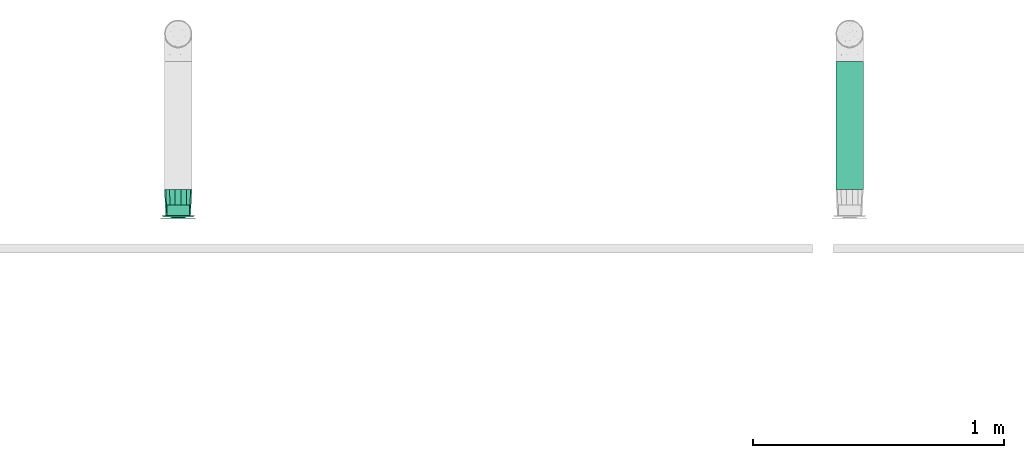
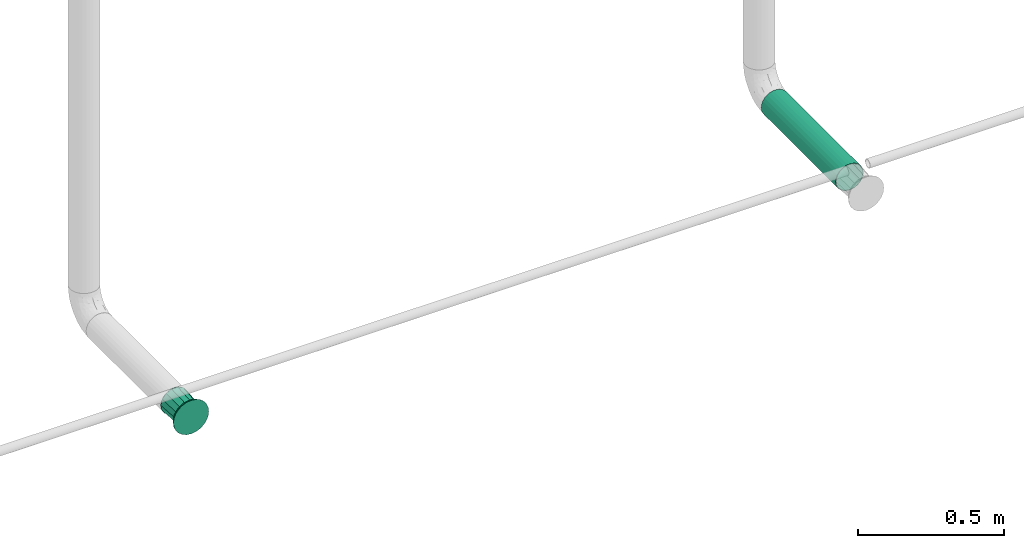
# One storey, part 93 of 123: 1 flow fitting, 1 flow segment, 1 flow terminal.
"""IFC2X3 building model written with IfcOpenShell, lengths in millimetres."""

from ifc_helpers import new_model, entity, si_unit, converted_unit, derived_unit, direction, frame, origin_with_axes, origin_2d_with_axis, place, context, subcontext, project, spatial, hollow_circle, extrude, open_shell, surface_model, source, transform, mapped, material, layer, layer_set, layer_usage, type_object, element, save


model = new_model("IFC2X3")

# Units and contexts
model_context = context("Model", 3, precision=1e-05, world=origin_with_axes(), true_north=direction((0.0, 1.0)))
body_context = subcontext(model_context, "Body", "Model", "MODEL_VIEW")
ifc_project = project(units=[si_unit("AREAUNIT", "SQUARE_METRE"), si_unit("VOLUMEUNIT", "CUBIC_METRE", prefix="DECI"), si_unit("TIMEUNIT", "SECOND"), si_unit("THERMODYNAMICTEMPERATUREUNIT", "DEGREE_CELSIUS"), si_unit("PRESSUREUNIT", "PASCAL"), si_unit("MASSUNIT", "GRAM", prefix="KILO"), si_unit("LENGTHUNIT", "METRE", prefix="MILLI"), si_unit("POWERUNIT", "WATT"), si_unit("ELECTRICCURRENTUNIT", "AMPERE"), si_unit("ELECTRICVOLTAGEUNIT", "VOLT"), derived_unit("VOLUMETRICFLOWRATEUNIT", [(si_unit("VOLUMEUNIT", "CUBIC_METRE", prefix="DECI"), 1), (si_unit("TIMEUNIT", "SECOND"), -1)]), derived_unit("LINEARVELOCITYUNIT", [(si_unit("LENGTHUNIT", "METRE"), 1), (si_unit("TIMEUNIT", "SECOND"), -1)]), derived_unit("MASSDENSITYUNIT", [(si_unit("MASSUNIT", "GRAM", prefix="KILO"), 1), (si_unit("VOLUMEUNIT", "CUBIC_METRE"), -1)]), converted_unit("PLANEANGLEUNIT", "DEGREE", entity("IfcRatioMeasure", 0.01745), si_unit("PLANEANGLEUNIT", "RADIAN"), dimensions=[0, 0, 0, 0, 0, 0, 0])], contexts=[model_context])

# Site, building, storey
site_placement = place(None, origin_with_axes())
site = spatial("IfcSite", under=ifc_project, at=site_placement, CompositionType="ELEMENT")
building_placement = place(site_placement, origin_with_axes())
building = spatial("IfcBuilding", under=site, at=building_placement, Name="mc-building", CompositionType="ELEMENT")
storey_placement = place(building_placement, origin_with_axes())
storey = spatial("IfcBuildingStorey", under=building, at=storey_placement, Name="1. Korrus", CompositionType="ELEMENT", Elevation=0.0)

# Flow terminal
air_terminal_type = type_object("IfcAirTerminalType", Name="100", PredefinedType="NOTDEFINED")
shared_shape_1 = source(origin_with_axes(), body_context, "Body", "SurfaceModel", [
    surface_model("IfcShellBasedSurfaceModel", [(11.2, 18.11733, -67.61481), (11.2, -18.11733, -67.61481), (11.2, 0.0, -70.0), (11.2, 67.61481, -18.11733), (11.2, 35.0, -60.62178), (11.2, 49.49747, -49.49747), (11.2, 60.62178, -35.0), (11.2, -67.61481, 18.11733), (11.2, -49.49747, -49.49747), (11.2, -67.61481, -18.11733), (11.2, -35.0, -60.62178), (11.2, -60.62178, -35.0), (11.2, -70.0, 0.0), (11.2, 18.11733, 67.61481), (11.2, 70.0, 0.0), (11.2, 67.61481, 18.11733), (11.2, 49.49747, 49.49747), (11.2, 60.62178, 35.0), (11.2, 35.0, 60.62178), (11.2, -49.49747, 49.49747), (11.2, -60.62178, 35.0), (11.2, -35.0, 60.62178), (11.2, -18.11733, 67.61481), (11.2, 0.0, 70.0), (9.2, 18.11733, 67.61481), (9.2, -67.61481, 18.11733), (9.2, 0.0, 70.0), (9.2, 49.49747, 49.49747), (9.2, 35.0, 60.62178), (9.2, 60.62178, 35.0), (9.2, 67.61481, 18.11733), (9.2, -35.0, 60.62178), (9.2, -49.49747, 49.49747), (9.2, -18.11733, 67.61481), (9.2, -60.62178, 35.0), (9.2, -67.61481, -18.11733), (9.2, -70.0, 0.0), (9.2, 67.61481, -18.11733), (9.2, 18.11733, -67.61481), (9.2, 49.49747, -49.49747), (9.2, 60.62178, -35.0), (9.2, 35.0, -60.62178), (9.2, -18.11733, -67.61481), (9.2, -49.49747, -49.49747), (9.2, -60.62178, -35.0), (9.2, -35.0, -60.62178), (9.2, 0.0, -70.0), (9.2, 70.0, 0.0), (9.2, 32.75, 0.0), (9.2, -16.375, 28.36233), (9.2, -28.36233, 16.375), (9.2, 16.375, 28.36233), (9.2, 0.0, 32.75), (9.2, 28.36233, 16.375), (9.2, -32.75, 0.0), (9.2, -16.375, -28.36233), (9.2, 16.375, -28.36233), (9.2, 0.0, -32.75), (9.2, 28.36233, -16.375), (9.2, -28.36233, -16.375), (6.2, -21.19625, -15.39997), (6.2, -21.19625, 15.39997), (6.2, 8.09625, 24.91768), (6.2, -8.09625, 24.91768), (6.2, -26.2, 0.0), (6.2, 21.19625, 15.39997), (6.2, -8.09625, -24.91768), (6.2, 21.19625, -15.39997), (6.2, 8.09625, -24.91768), (6.2, 26.2, 0.0), (9.2, 31.06579, -6.28555), (6.2, 23.69812, -7.69999), (6.2, -14.64625, -20.15883), (9.2, -22.36867, -22.36867), (6.2, -23.69812, -7.69999), (9.2, -31.06579, -6.28555), (6.2, 14.64625, -20.15883), (9.2, 8.1875, -30.55617), (6.2, 0.0, -24.91768), (9.2, 22.36867, -22.36867), (9.2, -8.1875, -30.55617), (9.2, -31.06579, 6.28555), (6.2, -23.69812, 7.69999), (6.2, 14.64625, 20.15883), (9.2, 22.36867, 22.36867), (6.2, 23.69812, 7.69999), (9.2, 31.06579, 6.28555), (6.2, -14.64625, 20.15883), (9.2, -8.1875, 30.55617), (6.2, 0.0, 24.91768), (9.2, -22.36867, 22.36867), (9.2, 8.1875, 30.55617), (6.2, -13.11761, 57.472), (6.2, -36.75472, 46.08897), (6.2, -53.11211, 25.57744), (6.2, 36.75472, 46.08897), (6.2, -58.95, 0.0), (6.2, 13.11761, 57.472), (6.2, 53.11211, 25.57744), (6.2, -53.11211, -25.57744), (6.2, -36.75472, -46.08897), (6.2, -13.11761, -57.472), (6.2, 58.95, 0.0), (6.2, 53.11211, -25.57744), (6.2, 13.11761, -57.472), (6.2, 36.75472, -46.08897), (0.0, -60.51411, 25.06576), (0.0, 0.0, 65.5), (0.0, 25.06576, 60.51411), (0.0, 46.3155, 46.3155), (0.0, 60.51411, 25.06576), (0.0, -46.3155, 46.3155), (0.0, -25.06576, 60.51411), (0.0, 0.0, -65.5), (0.0, -65.5, 0.0), (0.0, 65.5, 0.0), (0.0, 60.51411, -25.06576), (0.0, 46.3155, -46.3155), (0.0, 25.06576, -60.51411), (0.0, -46.3155, -46.3155), (0.0, -60.51411, -25.06576), (0.0, -25.06576, -60.51411), (6.2, 56.03105, -12.78872), (0.0, 53.4148, -35.69063), (0.0, 35.69063, -53.4148), (6.2, 24.93616, -51.78048), (0.0, -12.53288, -63.00706), (6.2, 0.0, -57.472), (0.0, -35.69063, -53.4148), (0.0, 63.00706, -12.53288), (6.2, 44.93342, -35.83321), (6.2, -24.93616, -51.78048), (6.2, -44.93342, -35.83321), (0.0, -53.4148, -35.69063), (0.0, 12.53288, -63.00706), (6.2, -56.03105, -12.78872), (0.0, -63.00706, -12.53288), (6.2, -56.03105, 12.78872), (0.0, -53.4148, 35.69063), (0.0, -35.69063, 53.4148), (6.2, -24.93616, 51.78048), (0.0, 12.53288, 63.00706), (6.2, 0.0, 57.472), (0.0, 35.69063, 53.4148), (0.0, -63.00706, 12.53288), (6.2, -44.93342, 35.83321), (6.2, 24.93616, 51.78048), (6.2, 44.93342, 35.83321), (0.0, 53.4148, 35.69063), (0.0, -12.53288, 63.00706), (6.2, 56.03105, 12.78872), (0.0, 63.00706, 12.53288), (-3.1, 12.94095, 48.29629), (-3.1, -35.35534, 35.35534), (-3.1, 0.0, 50.0), (-3.1, 35.35534, 35.35534), (-3.1, 25.0, 43.30127), (-3.1, -43.30127, 25.0), (-3.1, 43.30127, 25.0), (-3.1, -48.29629, -12.94095), (-3.1, -12.94095, 48.29629), (-3.1, -25.0, 43.30127), (-3.1, -50.0, 0.0), (-3.1, -48.29629, 12.94095), (-3.1, 48.29629, 12.94095), (-3.1, 12.94095, -48.29629), (-3.1, 50.0, 0.0), (-3.1, 48.29629, -12.94095), (-3.1, 35.35534, -35.35534), (-3.1, 43.30127, -25.0), (-3.1, 25.0, -43.30127), (-3.1, 0.0, -50.0), (-3.1, -35.35534, -35.35534), (-3.1, -43.30127, -25.0), (-3.1, -25.0, -43.30127), (-3.1, -12.94095, -48.29629), (0.0, 25.0, -43.30127), (0.0, 0.0, -50.0), (0.0, 12.94095, -48.29629), (0.0, 48.29629, -12.94095), (0.0, 35.35534, -35.35534), (0.0, -25.0, -43.30127), (0.0, 43.30127, -25.0), (0.0, -50.0, 0.0), (0.0, -12.94095, -48.29629), (0.0, -35.35534, -35.35534), (0.0, -48.29629, -12.94095), (0.0, -43.30127, -25.0), (0.0, 50.0, 0.0), (0.0, 43.30127, 25.0), (0.0, 12.94095, 48.29629), (0.0, 35.35534, 35.35534), (0.0, 25.0, 43.30127), (0.0, 0.0, 50.0), (0.0, -35.35534, 35.35534), (0.0, -43.30127, 25.0), (0.0, -48.29629, 12.94095), (0.0, -12.94095, 48.29629), (0.0, -25.0, 43.30127), (0.0, 48.29629, 12.94095), (-43.1, 0.0, 45.0), (-43.1, 11.64686, 43.46666), (-43.1, 22.5, 38.97115), (-43.1, -11.64686, 43.46666), (-43.1, 38.97115, 22.5), (-43.1, 43.46666, 11.64686), (-43.1, 31.81981, 31.81981), (-43.1, -22.5, 38.97115), (-43.1, -43.46666, 11.64686), (-43.1, -31.81981, 31.81981), (-43.1, -38.97115, 22.5), (-43.1, -45.0, 0.0), (-43.1, -43.46666, -11.64686), (-43.1, 45.0, 0.0), (-43.1, 43.46666, -11.64686), (-43.1, 38.97115, -22.5), (-43.1, 31.81981, -31.81981), (-43.1, 22.5, -38.97115), (-43.1, 11.64686, -43.46666), (-43.1, -31.81981, -31.81981), (-43.1, -38.97115, -22.5), (-43.1, -22.5, -38.97115), (-43.1, 0.0, -45.0), (-43.1, -11.64686, -43.46666), (-3.1, 22.5, -38.97115), (-3.1, 0.0, -45.0), (-3.1, 11.64686, -43.46666), (-3.1, 31.81981, -31.81981), (-3.1, -22.5, -38.97115), (-3.1, 38.97115, -22.5), (-3.1, 43.46666, -11.64686), (-3.1, 45.0, 0.0), (-3.1, -45.0, 0.0), (-3.1, -11.64686, -43.46666), (-3.1, -31.81981, -31.81981), (-3.1, -43.46666, -11.64686), (-3.1, -38.97115, -22.5), (-3.1, 0.0, 45.0), (-3.1, 43.46666, 11.64686), (-3.1, 38.97115, 22.5), (-3.1, 22.5, 38.97115), (-3.1, 31.81981, 31.81981), (-3.1, 11.64686, 43.46666), (-3.1, -11.64686, 43.46666), (-3.1, -43.46666, 11.64686), (-3.1, -31.81981, 31.81981), (-3.1, -38.97115, 22.5), (-3.1, -22.5, 38.97115)], [open_shell([[[0, 1, 2]], [[3, 0, 4]], [[5, 6, 3]], [[5, 3, 4]], [[7, 1, 0]], [[8, 7, 9]], [[10, 7, 8]], [[8, 9, 11]], [[12, 9, 7]], [[1, 7, 10]], [[7, 0, 3]], [[13, 14, 15]], [[16, 15, 17]], [[16, 18, 13]], [[16, 13, 15]], [[14, 13, 7]], [[7, 19, 20]], [[19, 7, 21]], [[7, 22, 21]], [[22, 7, 23]], [[7, 13, 23]], [[14, 7, 3]], [[24, 25, 26]], [[27, 24, 28]], [[27, 29, 30]], [[27, 30, 24]], [[25, 24, 30]], [[31, 25, 32]], [[25, 31, 33]], [[32, 25, 34]], [[33, 26, 25]], [[25, 35, 36]], [[25, 30, 37]], [[25, 37, 38]], [[39, 37, 40]], [[39, 41, 38]], [[39, 38, 37]], [[38, 42, 25]], [[35, 43, 44]], [[35, 25, 43]], [[45, 43, 25]], [[42, 45, 25]], [[38, 46, 42]], [[37, 30, 47]], [[35, 9, 36]], [[44, 11, 35]], [[10, 43, 45]], [[44, 43, 8]], [[1, 45, 42]], [[35, 11, 9]], [[9, 12, 36]], [[1, 10, 45]], [[8, 43, 10]], [[8, 11, 44]], [[2, 1, 42]], [[42, 46, 2]], [[38, 0, 46]], [[41, 4, 38]], [[6, 39, 40]], [[41, 39, 5]], [[3, 40, 37]], [[41, 5, 4]], [[4, 0, 38]], [[14, 3, 37]], [[6, 40, 3]], [[6, 5, 39]], [[47, 14, 37]], [[46, 0, 2]], [[30, 15, 47]], [[29, 17, 30]], [[18, 27, 28]], [[29, 27, 16]], [[13, 28, 24]], [[30, 17, 15]], [[15, 14, 47]], [[13, 18, 28]], [[16, 27, 18]], [[16, 17, 29]], [[23, 13, 24]], [[24, 26, 23]], [[33, 22, 26]], [[31, 21, 33]], [[20, 32, 34]], [[31, 32, 19]], [[7, 34, 25]], [[31, 19, 21]], [[21, 22, 33]], [[12, 7, 25]], [[20, 34, 7]], [[20, 19, 32]], [[36, 12, 25]], [[26, 22, 23]], [[48, 49, 50]], [[48, 51, 49]], [[49, 51, 52]], [[53, 51, 48]], [[48, 50, 54]], [[54, 55, 48]], [[56, 55, 57]], [[55, 58, 48]], [[58, 55, 56]], [[55, 54, 59]], [[60, 61, 62]], [[62, 61, 63]], [[64, 61, 60]], [[62, 65, 66]], [[67, 68, 65]], [[66, 60, 62]], [[65, 68, 66]], [[69, 67, 65]], [[69, 48, 70]], [[58, 71, 70]], [[72, 73, 60]], [[59, 74, 60]], [[75, 64, 74]], [[56, 68, 76]], [[72, 66, 55]], [[73, 72, 55]], [[68, 77, 78]], [[64, 75, 54]], [[59, 75, 74]], [[70, 71, 69]], [[67, 79, 76]], [[80, 55, 66]], [[68, 56, 77]], [[56, 76, 79]], [[79, 67, 58]], [[71, 58, 67]], [[80, 78, 57]], [[77, 57, 78]], [[66, 78, 80]], [[59, 60, 73]], [[64, 54, 81]], [[50, 82, 81]], [[83, 84, 65]], [[53, 85, 65]], [[86, 69, 85]], [[49, 63, 87]], [[83, 62, 51]], [[84, 83, 51]], [[63, 88, 89]], [[69, 86, 48]], [[53, 86, 85]], [[81, 82, 64]], [[61, 90, 87]], [[91, 51, 62]], [[63, 49, 88]], [[49, 87, 90]], [[90, 61, 50]], [[82, 50, 61]], [[91, 89, 52]], [[88, 52, 89]], [[62, 89, 91]], [[53, 65, 84]], [[92, 93, 94]], [[95, 94, 96]], [[97, 92, 95]], [[95, 92, 94]], [[96, 98, 95]], [[96, 99, 98]], [[99, 100, 101]], [[101, 102, 98]], [[102, 101, 103]], [[104, 105, 103]], [[101, 104, 103]], [[101, 98, 99]], [[106, 107, 108]], [[109, 110, 108]], [[106, 108, 110]], [[111, 112, 106]], [[106, 112, 107]], [[106, 113, 114]], [[106, 110, 113]], [[115, 116, 117]], [[117, 113, 110]], [[113, 117, 118]], [[114, 119, 120]], [[121, 119, 114]], [[121, 114, 113]], [[115, 117, 110]], [[103, 116, 122]], [[123, 116, 103]], [[124, 125, 118]], [[101, 126, 127]], [[100, 119, 128]], [[102, 122, 129]], [[103, 130, 123]], [[102, 129, 115]], [[113, 127, 126]], [[125, 124, 105]], [[130, 105, 117]], [[118, 125, 104]], [[124, 117, 105]], [[131, 100, 128]], [[119, 100, 132]], [[133, 99, 120]], [[134, 118, 104]], [[122, 116, 129]], [[127, 134, 104]], [[131, 121, 101]], [[99, 133, 132]], [[128, 121, 131]], [[130, 117, 123]], [[101, 121, 126]], [[99, 135, 120]], [[96, 136, 135]], [[136, 120, 135]], [[134, 127, 113]], [[133, 119, 132]], [[136, 96, 114]], [[94, 106, 137]], [[138, 106, 94]], [[139, 140, 112]], [[97, 141, 142]], [[95, 109, 143]], [[96, 137, 144]], [[94, 145, 138]], [[96, 144, 114]], [[107, 142, 141]], [[140, 139, 93]], [[145, 93, 111]], [[112, 140, 92]], [[139, 111, 93]], [[146, 95, 143]], [[109, 95, 147]], [[148, 98, 110]], [[149, 112, 92]], [[137, 106, 144]], [[142, 149, 92]], [[146, 108, 97]], [[98, 148, 147]], [[143, 108, 146]], [[145, 111, 138]], [[97, 108, 141]], [[98, 150, 110]], [[102, 151, 150]], [[151, 110, 150]], [[149, 142, 107]], [[148, 109, 147]], [[151, 102, 115]], [[152, 153, 154]], [[155, 152, 156]], [[157, 152, 158]], [[158, 152, 155]], [[158, 159, 157]], [[160, 153, 161]], [[160, 154, 153]], [[157, 162, 163]], [[153, 152, 157]], [[157, 159, 162]], [[158, 164, 159]], [[165, 166, 167]], [[168, 167, 169]], [[170, 165, 167]], [[170, 167, 168]], [[166, 165, 171]], [[159, 172, 173]], [[172, 159, 174]], [[174, 171, 175]], [[159, 164, 174]], [[166, 171, 174]], [[174, 164, 166]], [[176, 177, 178]], [[179, 176, 180]], [[176, 179, 181]], [[179, 180, 182]], [[179, 183, 181]], [[177, 181, 184]], [[177, 176, 181]], [[185, 186, 187]], [[186, 185, 181]], [[181, 183, 186]], [[183, 179, 188]], [[183, 188, 189]], [[190, 189, 191]], [[189, 190, 183]], [[190, 191, 192]], [[193, 194, 190]], [[183, 195, 196]], [[183, 190, 195]], [[194, 197, 198]], [[194, 195, 190]], [[197, 194, 193]], [[189, 188, 199]], [[164, 199, 166]], [[158, 189, 164]], [[192, 155, 156]], [[158, 155, 191]], [[190, 156, 152]], [[164, 189, 199]], [[199, 188, 166]], [[190, 192, 156]], [[191, 155, 192]], [[191, 189, 158]], [[193, 190, 152]], [[152, 154, 193]], [[160, 197, 154]], [[161, 198, 160]], [[195, 153, 157]], [[161, 153, 194]], [[196, 157, 163]], [[161, 194, 198]], [[198, 197, 160]], [[183, 196, 163]], [[195, 157, 196]], [[195, 194, 153]], [[162, 183, 163]], [[154, 197, 193]], [[159, 186, 162]], [[173, 187, 159]], [[181, 172, 174]], [[173, 172, 185]], [[184, 174, 175]], [[159, 187, 186]], [[186, 183, 162]], [[184, 181, 174]], [[185, 172, 181]], [[185, 187, 173]], [[177, 184, 175]], [[175, 171, 177]], [[165, 178, 171]], [[170, 176, 165]], [[182, 168, 169]], [[170, 168, 180]], [[179, 169, 167]], [[170, 180, 176]], [[176, 178, 165]], [[188, 179, 167]], [[182, 169, 179]], [[182, 180, 168]], [[166, 188, 167]], [[171, 178, 177]], [[200, 201, 202]], [[203, 200, 202]], [[204, 205, 202]], [[204, 202, 206]], [[203, 202, 205]], [[207, 208, 209]], [[207, 203, 205]], [[209, 208, 210]], [[211, 208, 212]], [[208, 207, 212]], [[207, 205, 212]], [[213, 214, 215]], [[205, 215, 212]], [[212, 216, 217]], [[216, 212, 215]], [[218, 219, 217]], [[212, 219, 220]], [[212, 217, 219]], [[221, 222, 223]], [[222, 221, 219]], [[218, 222, 219]], [[215, 205, 213]], [[224, 225, 226]], [[227, 228, 224]], [[229, 230, 231]], [[228, 227, 229]], [[229, 232, 228]], [[225, 228, 233]], [[225, 224, 228]], [[234, 235, 236]], [[235, 234, 228]], [[228, 232, 235]], [[232, 229, 231]], [[237, 238, 239]], [[240, 239, 241]], [[240, 242, 237]], [[240, 237, 239]], [[238, 237, 243]], [[244, 245, 246]], [[247, 244, 232]], [[244, 247, 245]], [[232, 238, 247]], [[238, 243, 247]], [[238, 232, 231]], [[205, 238, 213]], [[204, 239, 205]], [[240, 206, 202]], [[204, 206, 241]], [[242, 202, 201]], [[205, 239, 238]], [[238, 231, 213]], [[240, 202, 242]], [[241, 206, 240]], [[241, 239, 204]], [[201, 237, 242]], [[201, 200, 237]], [[243, 203, 207]], [[209, 247, 207]], [[246, 210, 208]], [[209, 210, 245]], [[244, 208, 211]], [[203, 243, 200]], [[207, 247, 243]], [[200, 243, 237]], [[209, 245, 247]], [[210, 246, 245]], [[244, 246, 208]], [[211, 232, 244]], [[212, 235, 211]], [[220, 236, 212]], [[228, 219, 221]], [[220, 219, 234]], [[233, 221, 223]], [[212, 236, 235]], [[235, 232, 211]], [[233, 228, 221]], [[234, 219, 228]], [[234, 236, 220]], [[225, 233, 223]], [[223, 222, 225]], [[226, 218, 217]], [[216, 224, 217]], [[229, 215, 214]], [[216, 215, 227]], [[230, 214, 213]], [[218, 226, 222]], [[217, 224, 226]], [[222, 226, 225]], [[216, 227, 224]], [[215, 229, 227]], [[230, 229, 214]], [[213, 231, 230]]])]),
])
flow_terminal_placement = place(storey_placement, frame((23447.14677, 12939.66532, 2300.0), z_axis=(0.0, 0.0, 1.0), x_axis=(0.0, -1.0, 0.0)))
element("IfcFlowTerminal", 1, at=flow_terminal_placement, inside=storey, type_object=air_terminal_type, Name="100", context=body_context, shape_type="MappedRepresentation", body=[
    mapped(shared_shape_1, transform((0.0, 0.0, 0.0), scale=1.0)),
])

# Flow segment
ifc_material = material(Name="FZ1")
ifc_layer = layer(ifc_material, 0.0)
ifc_layer_set = layer_set([ifc_layer], Name="FZ1")
ifc_layer_usage = layer_usage(ifc_layer_set, "AXIS1", "POSITIVE", 0.0)
duct_segment_type = type_object("IfcDuctSegmentType", PredefinedType="RIGIDSEGMENT")
shared_shape_2 = source(origin_with_axes(), body_context, "Body", "SweptSolid", [
    extrude(hollow_circle(Radius=55.0, WallThickness=2.0, at=origin_2d_with_axis()), frame((0.0, 0.0, 0.0), z_axis=(1.0, 0.0, 0.0), x_axis=(0.0, 1.0, 0.0)), (0.0, 0.0, 1.0), 510.8),
])
flow_segment_placement = place(storey_placement, frame((26120.56538, 13042.76532, 2300.0), z_axis=(0.0, 0.0, 1.0), x_axis=(0.0, 1.0, 0.0)))
element("IfcFlowSegment", 2, at=flow_segment_placement, inside=storey, type_object=duct_segment_type, material=ifc_layer_usage, context=body_context, shape_type="MappedRepresentation", body=[
    mapped(shared_shape_2, transform((0.0, 0.0, 0.0), scale=1.0)),
])

# Flow fitting
duct_fitting_type = type_object("IfcDuctFittingType", PredefinedType="TRANSITION")
shared_shape_3 = source(origin_with_axes(), body_context, "Body", "SurfaceModel", [
    surface_model("IfcShellBasedSurfaceModel", [(0.0, 12.94095, 48.29629), (0.0, -35.35534, 35.35534), (0.0, 0.0, 50.0), (0.0, 35.35534, 35.35534), (0.0, 25.0, 43.30127), (0.0, 43.30127, 25.0), (0.0, 48.29629, 12.94095), (0.0, -12.94095, 48.29629), (0.0, -25.0, 43.30127), (0.0, -48.29629, 12.94095), (0.0, -43.30127, 25.0), (0.0, -25.0, -43.30127), (0.0, -48.29629, -12.94095), (0.0, -50.0, 0.0), (0.0, 48.29629, -12.94095), (0.0, 12.94095, -48.29629), (0.0, 43.30127, -25.0), (0.0, 35.35534, -35.35534), (0.0, 25.0, -43.30127), (0.0, -35.35534, -35.35534), (0.0, -43.30127, -25.0), (0.0, -12.94095, -48.29629), (0.0, 0.0, -50.0), (0.0, 50.0, 0.0), (100.0, -55.0, 0.0), (100.0, -12.23865, 53.62104), (100.0, -34.29194, 43.00073), (100.0, 49.55329, -23.86361), (100.0, 12.23865, 53.62104), (100.0, 34.29194, 43.00073), (100.0, 55.0, 0.0), (100.0, 49.55329, 23.86361), (100.0, -49.55329, 23.86361), (100.0, 12.23865, -53.62104), (100.0, -49.55329, -23.86361), (100.0, -34.29194, -43.00073), (100.0, 34.29194, -43.00073), (100.0, -12.23865, -53.62104), (0.0, 11.12605, 48.7464), (0.0, -11.12605, 48.7464), (0.0, 31.17449, 39.09157), (0.0, -45.04844, -21.69419), (0.0, -45.04844, 21.69419), (0.0, -31.17449, 39.09157), (0.0, 45.04844, 21.69419), (0.0, 45.04844, -21.69419), (0.0, 31.17449, -39.09157), (0.0, -31.17449, -39.09157), (0.0, -11.12605, -48.7464), (0.0, 11.12605, -48.7464), (0.0, -47.52422, -10.84709), (100.0, -41.92261, -33.43217), (0.0, -38.11147, -30.39288), (100.0, 41.92261, -33.43217), (0.0, 38.11147, -30.39288), (0.0, -21.15027, -43.91899), (100.0, -23.2653, -48.31088), (100.0, -52.32388, -11.72483), (100.0, 0.0, -53.62104), (0.0, 0.0, -48.7464), (100.0, 23.2653, -48.31088), (0.0, 21.15027, -43.91899), (100.0, 52.32388, -11.72483), (0.0, 47.52422, -10.84709), (0.0, 47.52422, 10.84709), (100.0, 41.92261, 33.43217), (0.0, 38.11147, 30.39288), (100.0, -41.92261, 33.43217), (0.0, -38.11147, 30.39288), (0.0, 21.15027, 43.91899), (100.0, 23.2653, 48.31088), (100.0, 52.32388, 11.72483), (100.0, 0.0, 53.62104), (0.0, 0.0, 48.7464), (100.0, -23.2653, 48.31088), (0.0, -21.15027, 43.91899), (100.0, -52.32388, 11.72483), (0.0, -47.52422, 10.84709), (100.0, 27.5, -47.63139), (100.0, 0.0, -55.0), (100.0, 14.23505, -53.12592), (100.0, 38.89087, -38.89087), (100.0, -27.5, -47.63139), (100.0, 47.63139, -27.5), (100.0, 53.12592, -14.23505), (100.0, -14.23505, -53.12592), (100.0, -47.63139, -27.5), (100.0, -38.89087, -38.89087), (100.0, -53.12592, -14.23505), (100.0, 53.12592, 14.23505), (100.0, 47.63139, 27.5), (100.0, 27.5, 47.63139), (100.0, 38.89087, 38.89087), (100.0, 14.23505, 53.12592), (100.0, 0.0, 55.0), (100.0, -47.63139, 27.5), (100.0, -53.12592, 14.23505), (100.0, -27.5, 47.63139), (100.0, -38.89087, 38.89087), (100.0, -14.23505, 53.12592), (98.0, 0.0, 55.0), (98.0, 14.23505, 53.12592), (98.0, 27.5, 47.63139), (98.0, 38.89087, 38.89087), (98.0, 47.63139, 27.5), (98.0, -47.63139, 27.5), (98.0, 53.12592, -14.23505), (98.0, -27.5, 47.63139), (98.0, -14.23505, 53.12592), (98.0, -38.89087, 38.89087), (98.0, -55.0, 0.0), (98.0, -53.12592, 14.23505), (98.0, 53.12592, 14.23505), (98.0, 47.63139, -27.5), (98.0, -27.5, -47.63139), (98.0, 0.0, -55.0), (98.0, 38.89087, -38.89087), (98.0, 27.5, -47.63139), (98.0, 14.23505, -53.12592), (98.0, -47.63139, -27.5), (98.0, -38.89087, -38.89087), (98.0, -53.12592, -14.23505), (98.0, -14.23505, -53.12592), (98.0, 55.0, 0.0), (2.0, 12.94095, -48.29629), (2.0, 25.0, -43.30127), (2.0, 35.35534, -35.35534), (2.0, 43.30127, -25.0), (2.0, 48.29629, -12.94095), (2.0, 0.0, -50.0), (2.0, 50.0, 0.0), (2.0, -25.0, -43.30127), (2.0, -12.94095, -48.29629), (2.0, -35.35534, -35.35534), (2.0, -48.29629, -12.94095), (2.0, -43.30127, -25.0), (2.0, -48.29629, 12.94095), (2.0, 48.29629, 12.94095), (2.0, 43.30127, 25.0), (2.0, 35.35534, 35.35534), (2.0, -35.35534, 35.35534), (2.0, 12.94095, 48.29629), (2.0, 25.0, 43.30127), (2.0, 0.0, 50.0), (2.0, -43.30127, 25.0), (2.0, -50.0, 0.0), (2.0, -12.94095, 48.29629), (2.0, -25.0, 43.30127)], [open_shell([[[0, 1, 2]], [[3, 0, 4]], [[3, 5, 6]], [[0, 3, 1]], [[6, 1, 3]], [[7, 1, 8]], [[7, 2, 1]], [[1, 9, 10]], [[9, 1, 11]], [[12, 13, 9]], [[11, 1, 6]], [[6, 14, 11]], [[15, 14, 16]], [[17, 18, 15]], [[17, 15, 16]], [[11, 14, 15]], [[12, 19, 20]], [[19, 12, 11]], [[15, 21, 11]], [[12, 9, 11]], [[22, 21, 15]], [[14, 6, 23]], [[24, 25, 26]], [[25, 27, 28]], [[29, 28, 27]], [[27, 30, 31]], [[31, 29, 27]], [[24, 26, 32]], [[33, 24, 34]], [[33, 34, 35]], [[36, 27, 33]], [[33, 27, 24]], [[35, 37, 33]], [[24, 27, 25]], [[38, 23, 39]], [[40, 23, 38]], [[41, 42, 43]], [[41, 13, 42]], [[23, 43, 39]], [[40, 44, 23]], [[41, 23, 45]], [[41, 45, 46]], [[47, 41, 48]], [[49, 48, 41]], [[41, 46, 49]], [[23, 41, 43]], [[34, 50, 41]], [[47, 51, 52]], [[45, 27, 53]], [[36, 54, 53]], [[55, 48, 56]], [[34, 57, 50]], [[57, 13, 50]], [[13, 57, 24]], [[55, 35, 47]], [[35, 51, 47]], [[51, 41, 52]], [[58, 59, 49]], [[60, 61, 46]], [[37, 59, 58]], [[62, 63, 23]], [[35, 55, 56]], [[23, 30, 62]], [[53, 54, 45]], [[48, 37, 56]], [[33, 49, 61]], [[49, 33, 58]], [[54, 36, 46]], [[63, 27, 45]], [[34, 41, 51]], [[33, 61, 60]], [[48, 59, 37]], [[27, 63, 62]], [[46, 36, 60]], [[31, 64, 44]], [[40, 65, 66]], [[42, 32, 67]], [[26, 68, 67]], [[69, 38, 70]], [[31, 71, 64]], [[71, 23, 64]], [[23, 71, 30]], [[69, 29, 40]], [[29, 65, 40]], [[65, 44, 66]], [[72, 73, 39]], [[74, 75, 43]], [[28, 73, 72]], [[76, 77, 13]], [[29, 69, 70]], [[13, 24, 76]], [[67, 68, 42]], [[38, 28, 70]], [[25, 39, 75]], [[39, 25, 72]], [[68, 26, 43]], [[77, 32, 42]], [[31, 44, 65]], [[25, 75, 74]], [[38, 73, 28]], [[32, 77, 76]], [[43, 26, 74]], [[78, 79, 80]], [[81, 82, 78]], [[82, 83, 84]], [[81, 83, 82]], [[30, 82, 84]], [[79, 82, 85]], [[79, 78, 82]], [[82, 86, 87]], [[82, 30, 86]], [[24, 88, 86]], [[86, 30, 89]], [[90, 24, 89]], [[91, 90, 92]], [[91, 93, 94]], [[90, 91, 24]], [[94, 95, 91]], [[24, 95, 96]], [[24, 91, 95]], [[94, 97, 98]], [[98, 95, 94]], [[97, 94, 99]], [[89, 24, 86]], [[100, 101, 102]], [[100, 102, 103]], [[100, 104, 105]], [[104, 100, 103]], [[106, 105, 104]], [[100, 107, 108]], [[100, 109, 107]], [[105, 110, 111]], [[109, 100, 105]], [[105, 106, 110]], [[106, 104, 112]], [[106, 113, 110]], [[113, 114, 110]], [[115, 116, 117]], [[113, 116, 115]], [[117, 118, 115]], [[119, 114, 120]], [[121, 110, 119]], [[114, 115, 122]], [[119, 110, 114]], [[115, 114, 113]], [[123, 106, 112]], [[121, 88, 110]], [[119, 86, 121]], [[82, 120, 114]], [[119, 120, 87]], [[85, 114, 122]], [[121, 86, 88]], [[88, 24, 110]], [[85, 82, 114]], [[87, 120, 82]], [[87, 86, 119]], [[79, 85, 122]], [[122, 115, 79]], [[118, 80, 115]], [[117, 78, 118]], [[83, 116, 113]], [[117, 116, 81]], [[84, 113, 106]], [[117, 81, 78]], [[78, 80, 118]], [[30, 84, 106]], [[83, 113, 84]], [[83, 81, 116]], [[123, 30, 106]], [[115, 80, 79]], [[112, 89, 123]], [[104, 90, 112]], [[91, 103, 102]], [[104, 103, 92]], [[93, 102, 101]], [[112, 90, 89]], [[89, 30, 123]], [[93, 91, 102]], [[92, 103, 91]], [[92, 90, 104]], [[94, 93, 101]], [[101, 100, 94]], [[108, 99, 100]], [[107, 97, 108]], [[95, 109, 105]], [[107, 109, 98]], [[96, 105, 111]], [[107, 98, 97]], [[97, 99, 108]], [[24, 96, 111]], [[95, 105, 96]], [[95, 98, 109]], [[110, 24, 111]], [[100, 99, 94]], [[124, 125, 126]], [[124, 126, 127]], [[124, 128, 129]], [[128, 124, 127]], [[129, 128, 130]], [[129, 131, 132]], [[129, 130, 131]], [[133, 134, 135]], [[134, 133, 131]], [[131, 136, 134]], [[131, 130, 137]], [[137, 138, 139]], [[140, 137, 139]], [[140, 139, 141]], [[141, 139, 142]], [[140, 141, 143]], [[136, 140, 144]], [[145, 134, 136]], [[140, 146, 147]], [[131, 140, 136]], [[143, 146, 140]], [[131, 137, 140]], [[12, 134, 13]], [[20, 135, 12]], [[131, 19, 11]], [[20, 19, 133]], [[132, 11, 21]], [[12, 135, 134]], [[134, 145, 13]], [[132, 131, 11]], [[133, 19, 131]], [[133, 135, 20]], [[129, 132, 21]], [[21, 22, 129]], [[15, 124, 22]], [[18, 125, 15]], [[127, 17, 16]], [[18, 17, 126]], [[128, 16, 14]], [[18, 126, 125]], [[125, 124, 15]], [[130, 128, 14]], [[127, 16, 128]], [[127, 126, 17]], [[23, 130, 14]], [[22, 124, 129]], [[6, 137, 23]], [[5, 138, 6]], [[142, 3, 4]], [[5, 3, 139]], [[141, 4, 0]], [[6, 138, 137]], [[137, 130, 23]], [[141, 142, 4]], [[139, 3, 142]], [[139, 138, 5]], [[143, 141, 0]], [[0, 2, 143]], [[7, 146, 2]], [[8, 147, 7]], [[144, 1, 10]], [[8, 1, 140]], [[136, 10, 9]], [[8, 140, 147]], [[147, 146, 7]], [[145, 136, 9]], [[144, 10, 136]], [[144, 140, 1]], [[13, 145, 9]], [[2, 146, 143]]])]),
])
flow_fitting_placement = place(storey_placement, frame((23447.14677, 12942.76532, 2300.0), z_axis=(0.0, 0.0, 1.0), x_axis=(0.0, 1.0, 0.0)))
element("IfcFlowFitting", 3, at=flow_fitting_placement, inside=storey, type_object=duct_fitting_type, context=body_context, shape_type="MappedRepresentation", body=[
    mapped(shared_shape_3, transform((0.0, 0.0, 0.0), scale=1.0)),
])

save(model, "model.ifc")
